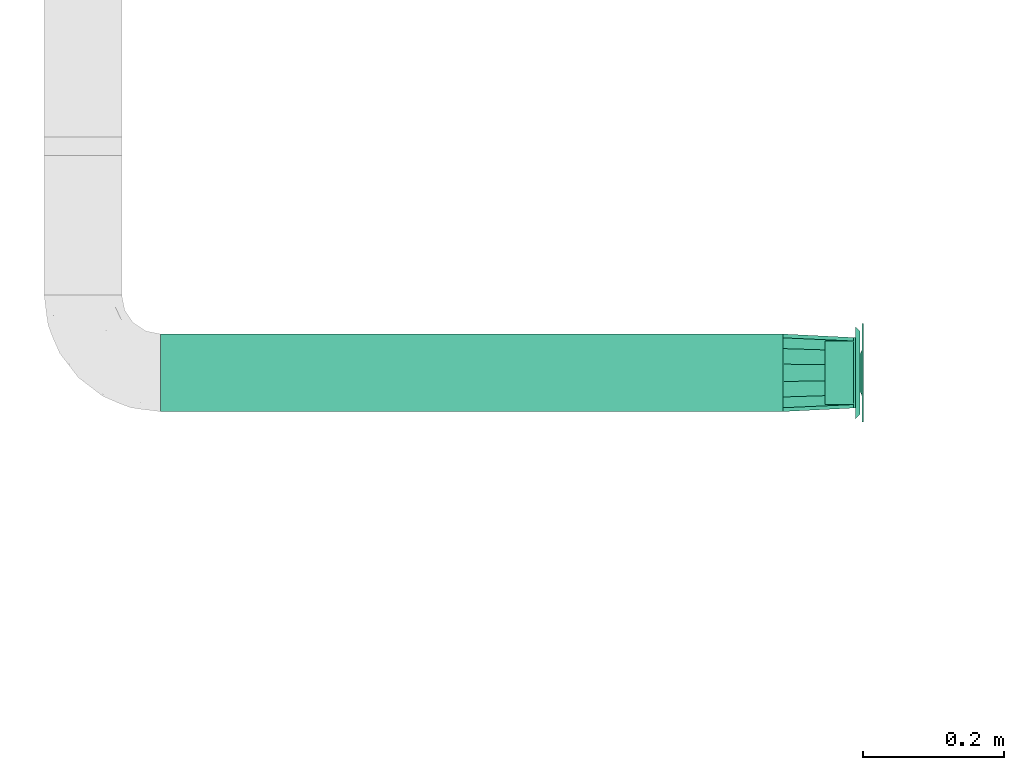
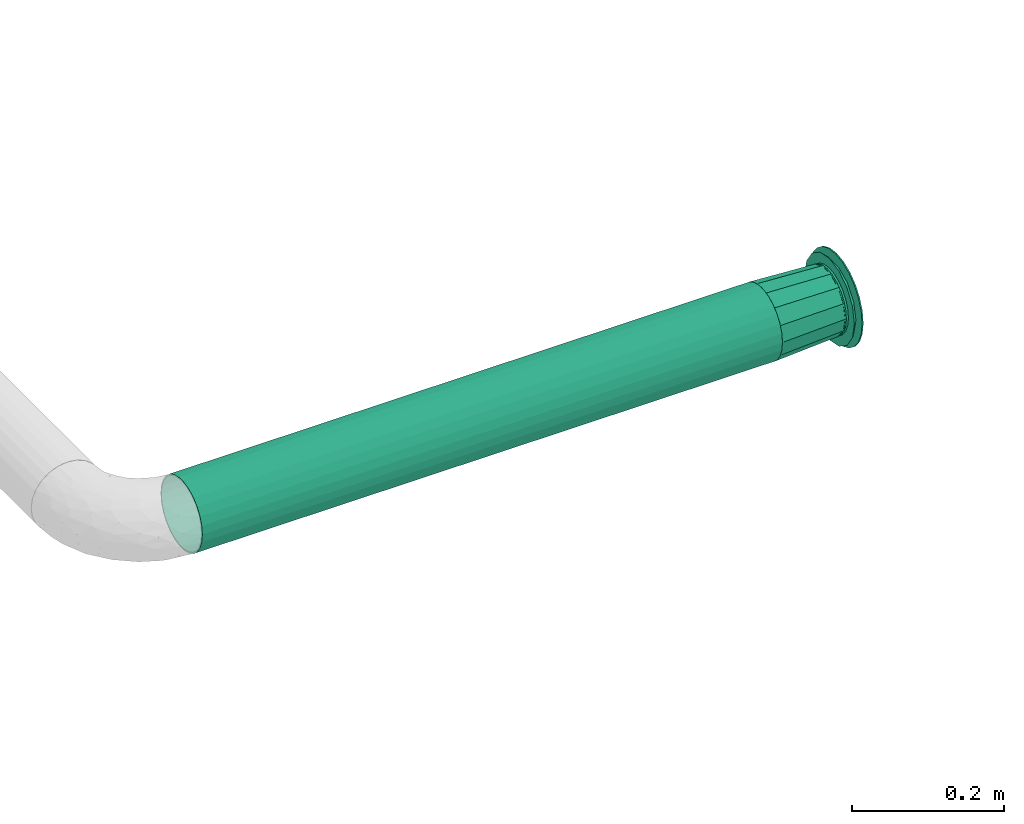
# One storey, part 21 of 103: 1 flow fitting, 1 flow segment, 1 flow terminal.
"""IFC2X3 building model written with IfcOpenShell, lengths in millimetres."""

from ifc_helpers import new_model, entity, si_unit, converted_unit, derived_unit, direction, frame, origin_with_axes, origin_2d_with_axis, place, context, subcontext, project, spatial, hollow_circle, extrude, open_shell, surface_model, source, transform, mapped, material, layer, layer_set, layer_usage, type_object, element, save


model = new_model("IFC2X3")

# Units and contexts
model_context = context("Model", 3, precision=1e-05, world=origin_with_axes(), true_north=direction((0.0, 1.0)))
body_context = subcontext(model_context, "Body", "Model", "MODEL_VIEW")
ifc_project = project(units=[si_unit("AREAUNIT", "SQUARE_METRE"), si_unit("VOLUMEUNIT", "CUBIC_METRE", prefix="DECI"), si_unit("TIMEUNIT", "SECOND"), si_unit("THERMODYNAMICTEMPERATUREUNIT", "DEGREE_CELSIUS"), si_unit("PRESSUREUNIT", "PASCAL"), si_unit("MASSUNIT", "GRAM", prefix="KILO"), si_unit("LENGTHUNIT", "METRE", prefix="MILLI"), si_unit("POWERUNIT", "WATT"), si_unit("ELECTRICCURRENTUNIT", "AMPERE"), si_unit("ELECTRICVOLTAGEUNIT", "VOLT"), derived_unit("VOLUMETRICFLOWRATEUNIT", [(si_unit("VOLUMEUNIT", "CUBIC_METRE", prefix="DECI"), 1), (si_unit("TIMEUNIT", "SECOND"), -1)]), derived_unit("LINEARVELOCITYUNIT", [(si_unit("LENGTHUNIT", "METRE"), 1), (si_unit("TIMEUNIT", "SECOND"), -1)]), derived_unit("MASSDENSITYUNIT", [(si_unit("MASSUNIT", "GRAM", prefix="KILO"), 1), (si_unit("VOLUMEUNIT", "CUBIC_METRE"), -1)]), converted_unit("PLANEANGLEUNIT", "DEGREE", entity("IfcRatioMeasure", 0.01745), si_unit("PLANEANGLEUNIT", "RADIAN"), dimensions=[0, 0, 0, 0, 0, 0, 0])], contexts=[model_context])

# Site, building, storey
site_placement = place(None, origin_with_axes())
site = spatial("IfcSite", under=ifc_project, at=site_placement, CompositionType="ELEMENT")
building_placement = place(site_placement, origin_with_axes())
building = spatial("IfcBuilding", under=site, at=building_placement, Name="mc-building", CompositionType="ELEMENT")
storey_placement = place(building_placement, frame((0.0, 0.0, 5900.0), z_axis=(0.0, 0.0, 1.0), x_axis=(1.0, 0.0, 0.0)))
storey = spatial("IfcBuildingStorey", under=building, at=storey_placement, Name="3. Korrus", CompositionType="ELEMENT", Elevation=5900.0)

# Flow terminal
air_terminal_type = type_object("IfcAirTerminalType", Name="100", PredefinedType="NOTDEFINED")
shared_shape_1 = source(origin_with_axes(), body_context, "Body", "SurfaceModel", [
    surface_model("IfcShellBasedSurfaceModel", [(11.2, 18.11733, -67.61481), (11.2, -18.11733, -67.61481), (11.2, 0.0, -70.0), (11.2, 67.61481, -18.11733), (11.2, 35.0, -60.62178), (11.2, 49.49747, -49.49747), (11.2, 60.62178, -35.0), (11.2, -67.61481, 18.11733), (11.2, -49.49747, -49.49747), (11.2, -67.61481, -18.11733), (11.2, -35.0, -60.62178), (11.2, -60.62178, -35.0), (11.2, -70.0, 0.0), (11.2, 18.11733, 67.61481), (11.2, 70.0, 0.0), (11.2, 67.61481, 18.11733), (11.2, 49.49747, 49.49747), (11.2, 60.62178, 35.0), (11.2, 35.0, 60.62178), (11.2, -49.49747, 49.49747), (11.2, -60.62178, 35.0), (11.2, -35.0, 60.62178), (11.2, -18.11733, 67.61481), (11.2, 0.0, 70.0), (9.2, 18.11733, 67.61481), (9.2, -67.61481, 18.11733), (9.2, 0.0, 70.0), (9.2, 49.49747, 49.49747), (9.2, 35.0, 60.62178), (9.2, 60.62178, 35.0), (9.2, 67.61481, 18.11733), (9.2, -35.0, 60.62178), (9.2, -49.49747, 49.49747), (9.2, -18.11733, 67.61481), (9.2, -60.62178, 35.0), (9.2, -67.61481, -18.11733), (9.2, -70.0, 0.0), (9.2, 67.61481, -18.11733), (9.2, 18.11733, -67.61481), (9.2, 49.49747, -49.49747), (9.2, 60.62178, -35.0), (9.2, 35.0, -60.62178), (9.2, -18.11733, -67.61481), (9.2, -49.49747, -49.49747), (9.2, -60.62178, -35.0), (9.2, -35.0, -60.62178), (9.2, 0.0, -70.0), (9.2, 70.0, 0.0), (9.2, 32.75, 0.0), (9.2, -16.375, 28.36233), (9.2, -28.36233, 16.375), (9.2, 16.375, 28.36233), (9.2, 0.0, 32.75), (9.2, 28.36233, 16.375), (9.2, -32.75, 0.0), (9.2, -16.375, -28.36233), (9.2, 16.375, -28.36233), (9.2, 0.0, -32.75), (9.2, 28.36233, -16.375), (9.2, -28.36233, -16.375), (6.2, -21.19625, -15.39997), (6.2, -21.19625, 15.39997), (6.2, 8.09625, 24.91768), (6.2, -8.09625, 24.91768), (6.2, -26.2, 0.0), (6.2, 21.19625, 15.39997), (6.2, -8.09625, -24.91768), (6.2, 21.19625, -15.39997), (6.2, 8.09625, -24.91768), (6.2, 26.2, 0.0), (9.2, 31.06579, -6.28555), (6.2, 23.69812, -7.69999), (6.2, -14.64625, -20.15883), (9.2, -22.36867, -22.36867), (6.2, -23.69812, -7.69999), (9.2, -31.06579, -6.28555), (6.2, 14.64625, -20.15883), (9.2, 8.1875, -30.55617), (6.2, 0.0, -24.91768), (9.2, 22.36867, -22.36867), (9.2, -8.1875, -30.55617), (9.2, -31.06579, 6.28555), (6.2, -23.69812, 7.69999), (6.2, 14.64625, 20.15883), (9.2, 22.36867, 22.36867), (6.2, 23.69812, 7.69999), (9.2, 31.06579, 6.28555), (6.2, -14.64625, 20.15883), (9.2, -8.1875, 30.55617), (6.2, 0.0, 24.91768), (9.2, -22.36867, 22.36867), (9.2, 8.1875, 30.55617), (6.2, -13.11761, 57.472), (6.2, -36.75472, 46.08897), (6.2, -53.11211, 25.57744), (6.2, 36.75472, 46.08897), (6.2, -58.95, 0.0), (6.2, 13.11761, 57.472), (6.2, 53.11211, 25.57744), (6.2, -53.11211, -25.57744), (6.2, -36.75472, -46.08897), (6.2, -13.11761, -57.472), (6.2, 58.95, 0.0), (6.2, 53.11211, -25.57744), (6.2, 13.11761, -57.472), (6.2, 36.75472, -46.08897), (0.0, -60.51411, 25.06576), (0.0, 0.0, 65.5), (0.0, 25.06576, 60.51411), (0.0, 46.3155, 46.3155), (0.0, 60.51411, 25.06576), (0.0, -46.3155, 46.3155), (0.0, -25.06576, 60.51411), (0.0, 0.0, -65.5), (0.0, -65.5, 0.0), (0.0, 65.5, 0.0), (0.0, 60.51411, -25.06576), (0.0, 46.3155, -46.3155), (0.0, 25.06576, -60.51411), (0.0, -46.3155, -46.3155), (0.0, -60.51411, -25.06576), (0.0, -25.06576, -60.51411), (6.2, 56.03105, -12.78872), (0.0, 53.4148, -35.69063), (0.0, 35.69063, -53.4148), (6.2, 24.93616, -51.78048), (0.0, -12.53288, -63.00706), (6.2, 0.0, -57.472), (0.0, -35.69063, -53.4148), (0.0, 63.00706, -12.53288), (6.2, 44.93342, -35.83321), (6.2, -24.93616, -51.78048), (6.2, -44.93342, -35.83321), (0.0, -53.4148, -35.69063), (0.0, 12.53288, -63.00706), (6.2, -56.03105, -12.78872), (0.0, -63.00706, -12.53288), (6.2, -56.03105, 12.78872), (0.0, -53.4148, 35.69063), (0.0, -35.69063, 53.4148), (6.2, -24.93616, 51.78048), (0.0, 12.53288, 63.00706), (6.2, 0.0, 57.472), (0.0, 35.69063, 53.4148), (0.0, -63.00706, 12.53288), (6.2, -44.93342, 35.83321), (6.2, 24.93616, 51.78048), (6.2, 44.93342, 35.83321), (0.0, 53.4148, 35.69063), (0.0, -12.53288, 63.00706), (6.2, 56.03105, 12.78872), (0.0, 63.00706, 12.53288), (-3.1, 12.94095, 48.29629), (-3.1, -35.35534, 35.35534), (-3.1, 0.0, 50.0), (-3.1, 35.35534, 35.35534), (-3.1, 25.0, 43.30127), (-3.1, -43.30127, 25.0), (-3.1, 43.30127, 25.0), (-3.1, -48.29629, -12.94095), (-3.1, -12.94095, 48.29629), (-3.1, -25.0, 43.30127), (-3.1, -50.0, 0.0), (-3.1, -48.29629, 12.94095), (-3.1, 48.29629, 12.94095), (-3.1, 12.94095, -48.29629), (-3.1, 50.0, 0.0), (-3.1, 48.29629, -12.94095), (-3.1, 35.35534, -35.35534), (-3.1, 43.30127, -25.0), (-3.1, 25.0, -43.30127), (-3.1, 0.0, -50.0), (-3.1, -35.35534, -35.35534), (-3.1, -43.30127, -25.0), (-3.1, -25.0, -43.30127), (-3.1, -12.94095, -48.29629), (0.0, 25.0, -43.30127), (0.0, 0.0, -50.0), (0.0, 12.94095, -48.29629), (0.0, 48.29629, -12.94095), (0.0, 35.35534, -35.35534), (0.0, -25.0, -43.30127), (0.0, 43.30127, -25.0), (0.0, -50.0, 0.0), (0.0, -12.94095, -48.29629), (0.0, -35.35534, -35.35534), (0.0, -48.29629, -12.94095), (0.0, -43.30127, -25.0), (0.0, 50.0, 0.0), (0.0, 43.30127, 25.0), (0.0, 12.94095, 48.29629), (0.0, 35.35534, 35.35534), (0.0, 25.0, 43.30127), (0.0, 0.0, 50.0), (0.0, -35.35534, 35.35534), (0.0, -43.30127, 25.0), (0.0, -48.29629, 12.94095), (0.0, -12.94095, 48.29629), (0.0, -25.0, 43.30127), (0.0, 48.29629, 12.94095), (-43.1, 0.0, 45.0), (-43.1, 11.64686, 43.46666), (-43.1, 22.5, 38.97115), (-43.1, -11.64686, 43.46666), (-43.1, 38.97115, 22.5), (-43.1, 43.46666, 11.64686), (-43.1, 31.81981, 31.81981), (-43.1, -22.5, 38.97115), (-43.1, -43.46666, 11.64686), (-43.1, -31.81981, 31.81981), (-43.1, -38.97115, 22.5), (-43.1, -45.0, 0.0), (-43.1, -43.46666, -11.64686), (-43.1, 45.0, 0.0), (-43.1, 43.46666, -11.64686), (-43.1, 38.97115, -22.5), (-43.1, 31.81981, -31.81981), (-43.1, 22.5, -38.97115), (-43.1, 11.64686, -43.46666), (-43.1, -31.81981, -31.81981), (-43.1, -38.97115, -22.5), (-43.1, -22.5, -38.97115), (-43.1, 0.0, -45.0), (-43.1, -11.64686, -43.46666), (-3.1, 22.5, -38.97115), (-3.1, 0.0, -45.0), (-3.1, 11.64686, -43.46666), (-3.1, 31.81981, -31.81981), (-3.1, -22.5, -38.97115), (-3.1, 38.97115, -22.5), (-3.1, 43.46666, -11.64686), (-3.1, 45.0, 0.0), (-3.1, -45.0, 0.0), (-3.1, -11.64686, -43.46666), (-3.1, -31.81981, -31.81981), (-3.1, -43.46666, -11.64686), (-3.1, -38.97115, -22.5), (-3.1, 0.0, 45.0), (-3.1, 43.46666, 11.64686), (-3.1, 38.97115, 22.5), (-3.1, 22.5, 38.97115), (-3.1, 31.81981, 31.81981), (-3.1, 11.64686, 43.46666), (-3.1, -11.64686, 43.46666), (-3.1, -43.46666, 11.64686), (-3.1, -31.81981, 31.81981), (-3.1, -38.97115, 22.5), (-3.1, -22.5, 38.97115)], [open_shell([[[0, 1, 2]], [[3, 0, 4]], [[5, 6, 3]], [[5, 3, 4]], [[7, 1, 0]], [[8, 7, 9]], [[10, 7, 8]], [[8, 9, 11]], [[12, 9, 7]], [[1, 7, 10]], [[7, 0, 3]], [[13, 14, 15]], [[16, 15, 17]], [[16, 18, 13]], [[16, 13, 15]], [[14, 13, 7]], [[7, 19, 20]], [[19, 7, 21]], [[7, 22, 21]], [[22, 7, 23]], [[7, 13, 23]], [[14, 7, 3]], [[24, 25, 26]], [[27, 24, 28]], [[27, 29, 30]], [[27, 30, 24]], [[25, 24, 30]], [[31, 25, 32]], [[25, 31, 33]], [[32, 25, 34]], [[33, 26, 25]], [[25, 35, 36]], [[25, 30, 37]], [[25, 37, 38]], [[39, 37, 40]], [[39, 41, 38]], [[39, 38, 37]], [[38, 42, 25]], [[35, 43, 44]], [[35, 25, 43]], [[45, 43, 25]], [[42, 45, 25]], [[38, 46, 42]], [[37, 30, 47]], [[35, 9, 36]], [[44, 11, 35]], [[10, 43, 45]], [[44, 43, 8]], [[1, 45, 42]], [[35, 11, 9]], [[9, 12, 36]], [[1, 10, 45]], [[8, 43, 10]], [[8, 11, 44]], [[2, 1, 42]], [[42, 46, 2]], [[38, 0, 46]], [[41, 4, 38]], [[6, 39, 40]], [[41, 39, 5]], [[3, 40, 37]], [[41, 5, 4]], [[4, 0, 38]], [[14, 3, 37]], [[6, 40, 3]], [[6, 5, 39]], [[47, 14, 37]], [[46, 0, 2]], [[30, 15, 47]], [[29, 17, 30]], [[18, 27, 28]], [[29, 27, 16]], [[13, 28, 24]], [[30, 17, 15]], [[15, 14, 47]], [[13, 18, 28]], [[16, 27, 18]], [[16, 17, 29]], [[23, 13, 24]], [[24, 26, 23]], [[33, 22, 26]], [[31, 21, 33]], [[20, 32, 34]], [[31, 32, 19]], [[7, 34, 25]], [[31, 19, 21]], [[21, 22, 33]], [[12, 7, 25]], [[20, 34, 7]], [[20, 19, 32]], [[36, 12, 25]], [[26, 22, 23]], [[48, 49, 50]], [[48, 51, 49]], [[49, 51, 52]], [[53, 51, 48]], [[48, 50, 54]], [[54, 55, 48]], [[56, 55, 57]], [[55, 58, 48]], [[58, 55, 56]], [[55, 54, 59]], [[60, 61, 62]], [[62, 61, 63]], [[64, 61, 60]], [[62, 65, 66]], [[67, 68, 65]], [[66, 60, 62]], [[65, 68, 66]], [[69, 67, 65]], [[69, 48, 70]], [[58, 71, 70]], [[72, 73, 60]], [[59, 74, 60]], [[75, 64, 74]], [[56, 68, 76]], [[72, 66, 55]], [[73, 72, 55]], [[68, 77, 78]], [[64, 75, 54]], [[59, 75, 74]], [[70, 71, 69]], [[67, 79, 76]], [[80, 55, 66]], [[68, 56, 77]], [[56, 76, 79]], [[79, 67, 58]], [[71, 58, 67]], [[80, 78, 57]], [[77, 57, 78]], [[66, 78, 80]], [[59, 60, 73]], [[64, 54, 81]], [[50, 82, 81]], [[83, 84, 65]], [[53, 85, 65]], [[86, 69, 85]], [[49, 63, 87]], [[83, 62, 51]], [[84, 83, 51]], [[63, 88, 89]], [[69, 86, 48]], [[53, 86, 85]], [[81, 82, 64]], [[61, 90, 87]], [[91, 51, 62]], [[63, 49, 88]], [[49, 87, 90]], [[90, 61, 50]], [[82, 50, 61]], [[91, 89, 52]], [[88, 52, 89]], [[62, 89, 91]], [[53, 65, 84]], [[92, 93, 94]], [[95, 94, 96]], [[97, 92, 95]], [[95, 92, 94]], [[96, 98, 95]], [[96, 99, 98]], [[99, 100, 101]], [[101, 102, 98]], [[102, 101, 103]], [[104, 105, 103]], [[101, 104, 103]], [[101, 98, 99]], [[106, 107, 108]], [[109, 110, 108]], [[106, 108, 110]], [[111, 112, 106]], [[106, 112, 107]], [[106, 113, 114]], [[106, 110, 113]], [[115, 116, 117]], [[117, 113, 110]], [[113, 117, 118]], [[114, 119, 120]], [[121, 119, 114]], [[121, 114, 113]], [[115, 117, 110]], [[103, 116, 122]], [[123, 116, 103]], [[124, 125, 118]], [[101, 126, 127]], [[100, 119, 128]], [[102, 122, 129]], [[103, 130, 123]], [[102, 129, 115]], [[113, 127, 126]], [[125, 124, 105]], [[130, 105, 117]], [[118, 125, 104]], [[124, 117, 105]], [[131, 100, 128]], [[119, 100, 132]], [[133, 99, 120]], [[134, 118, 104]], [[122, 116, 129]], [[127, 134, 104]], [[131, 121, 101]], [[99, 133, 132]], [[128, 121, 131]], [[130, 117, 123]], [[101, 121, 126]], [[99, 135, 120]], [[96, 136, 135]], [[136, 120, 135]], [[134, 127, 113]], [[133, 119, 132]], [[136, 96, 114]], [[94, 106, 137]], [[138, 106, 94]], [[139, 140, 112]], [[97, 141, 142]], [[95, 109, 143]], [[96, 137, 144]], [[94, 145, 138]], [[96, 144, 114]], [[107, 142, 141]], [[140, 139, 93]], [[145, 93, 111]], [[112, 140, 92]], [[139, 111, 93]], [[146, 95, 143]], [[109, 95, 147]], [[148, 98, 110]], [[149, 112, 92]], [[137, 106, 144]], [[142, 149, 92]], [[146, 108, 97]], [[98, 148, 147]], [[143, 108, 146]], [[145, 111, 138]], [[97, 108, 141]], [[98, 150, 110]], [[102, 151, 150]], [[151, 110, 150]], [[149, 142, 107]], [[148, 109, 147]], [[151, 102, 115]], [[152, 153, 154]], [[155, 152, 156]], [[157, 152, 158]], [[158, 152, 155]], [[158, 159, 157]], [[160, 153, 161]], [[160, 154, 153]], [[157, 162, 163]], [[153, 152, 157]], [[157, 159, 162]], [[158, 164, 159]], [[165, 166, 167]], [[168, 167, 169]], [[170, 165, 167]], [[170, 167, 168]], [[166, 165, 171]], [[159, 172, 173]], [[172, 159, 174]], [[174, 171, 175]], [[159, 164, 174]], [[166, 171, 174]], [[174, 164, 166]], [[176, 177, 178]], [[179, 176, 180]], [[176, 179, 181]], [[179, 180, 182]], [[179, 183, 181]], [[177, 181, 184]], [[177, 176, 181]], [[185, 186, 187]], [[186, 185, 181]], [[181, 183, 186]], [[183, 179, 188]], [[183, 188, 189]], [[190, 189, 191]], [[189, 190, 183]], [[190, 191, 192]], [[193, 194, 190]], [[183, 195, 196]], [[183, 190, 195]], [[194, 197, 198]], [[194, 195, 190]], [[197, 194, 193]], [[189, 188, 199]], [[164, 199, 166]], [[158, 189, 164]], [[192, 155, 156]], [[158, 155, 191]], [[190, 156, 152]], [[164, 189, 199]], [[199, 188, 166]], [[190, 192, 156]], [[191, 155, 192]], [[191, 189, 158]], [[193, 190, 152]], [[152, 154, 193]], [[160, 197, 154]], [[161, 198, 160]], [[195, 153, 157]], [[161, 153, 194]], [[196, 157, 163]], [[161, 194, 198]], [[198, 197, 160]], [[183, 196, 163]], [[195, 157, 196]], [[195, 194, 153]], [[162, 183, 163]], [[154, 197, 193]], [[159, 186, 162]], [[173, 187, 159]], [[181, 172, 174]], [[173, 172, 185]], [[184, 174, 175]], [[159, 187, 186]], [[186, 183, 162]], [[184, 181, 174]], [[185, 172, 181]], [[185, 187, 173]], [[177, 184, 175]], [[175, 171, 177]], [[165, 178, 171]], [[170, 176, 165]], [[182, 168, 169]], [[170, 168, 180]], [[179, 169, 167]], [[170, 180, 176]], [[176, 178, 165]], [[188, 179, 167]], [[182, 169, 179]], [[182, 180, 168]], [[166, 188, 167]], [[171, 178, 177]], [[200, 201, 202]], [[203, 200, 202]], [[204, 205, 202]], [[204, 202, 206]], [[203, 202, 205]], [[207, 208, 209]], [[207, 203, 205]], [[209, 208, 210]], [[211, 208, 212]], [[208, 207, 212]], [[207, 205, 212]], [[213, 214, 215]], [[205, 215, 212]], [[212, 216, 217]], [[216, 212, 215]], [[218, 219, 217]], [[212, 219, 220]], [[212, 217, 219]], [[221, 222, 223]], [[222, 221, 219]], [[218, 222, 219]], [[215, 205, 213]], [[224, 225, 226]], [[227, 228, 224]], [[229, 230, 231]], [[228, 227, 229]], [[229, 232, 228]], [[225, 228, 233]], [[225, 224, 228]], [[234, 235, 236]], [[235, 234, 228]], [[228, 232, 235]], [[232, 229, 231]], [[237, 238, 239]], [[240, 239, 241]], [[240, 242, 237]], [[240, 237, 239]], [[238, 237, 243]], [[244, 245, 246]], [[247, 244, 232]], [[244, 247, 245]], [[232, 238, 247]], [[238, 243, 247]], [[238, 232, 231]], [[205, 238, 213]], [[204, 239, 205]], [[240, 206, 202]], [[204, 206, 241]], [[242, 202, 201]], [[205, 239, 238]], [[238, 231, 213]], [[240, 202, 242]], [[241, 206, 240]], [[241, 239, 204]], [[201, 237, 242]], [[201, 200, 237]], [[243, 203, 207]], [[209, 247, 207]], [[246, 210, 208]], [[209, 210, 245]], [[244, 208, 211]], [[203, 243, 200]], [[207, 247, 243]], [[200, 243, 237]], [[209, 245, 247]], [[210, 246, 245]], [[244, 246, 208]], [[211, 232, 244]], [[212, 235, 211]], [[220, 236, 212]], [[228, 219, 221]], [[220, 219, 234]], [[233, 221, 223]], [[212, 236, 235]], [[235, 232, 211]], [[233, 228, 221]], [[234, 219, 228]], [[234, 236, 220]], [[225, 233, 223]], [[223, 222, 225]], [[226, 218, 217]], [[216, 224, 217]], [[229, 215, 214]], [[216, 215, 227]], [[230, 214, 213]], [[218, 226, 222]], [[217, 224, 226]], [[222, 226, 225]], [[216, 227, 224]], [[215, 229, 227]], [[230, 229, 214]], [[213, 231, 230]]])]),
])
flow_terminal_placement = place(storey_placement, frame((10289.07051, 3436.80698, 2345.0), z_axis=(0.0, 0.0, 1.0), x_axis=(1.0, 0.0, 0.0)))
element("IfcFlowTerminal", 1, at=flow_terminal_placement, inside=storey, type_object=air_terminal_type, Name="100", context=body_context, shape_type="MappedRepresentation", body=[
    mapped(shared_shape_1, transform((0.0, 0.0, 0.0), scale=1.0)),
])

# Flow segment
ifc_material = material(Name="FZ1")
ifc_layer = layer(ifc_material, 0.0)
ifc_layer_set = layer_set([ifc_layer], Name="FZ1")
ifc_layer_usage = layer_usage(ifc_layer_set, "AXIS1", "POSITIVE", 0.0)
duct_segment_type = type_object("IfcDuctSegmentType", Name="Safe", PredefinedType="RIGIDSEGMENT")
shared_shape_2 = source(origin_with_axes(), body_context, "Body", "SweptSolid", [
    extrude(hollow_circle(Radius=55.0, WallThickness=2.0, at=origin_2d_with_axis()), frame((0.0, 0.0, 0.0), z_axis=(1.0, 0.0, 0.0), x_axis=(0.0, 1.0, 0.0)), (0.0, 0.0, 1.0), 881.8),
])
flow_segment_placement = place(storey_placement, frame((9304.13313, 3436.80698, 2345.0), z_axis=(0.0, 0.0, 1.0), x_axis=(1.0, 0.0, 0.0)))
element("IfcFlowSegment", 2, at=flow_segment_placement, inside=storey, type_object=duct_segment_type, material=ifc_layer_usage, Name="Safe", context=body_context, shape_type="MappedRepresentation", body=[
    mapped(shared_shape_2, transform((0.0, 0.0, 0.0), scale=1.0)),
])

# Flow fitting
duct_fitting_type = type_object("IfcDuctFittingType", PredefinedType="TRANSITION")
shared_shape_3 = source(origin_with_axes(), body_context, "Body", "SurfaceModel", [
    surface_model("IfcShellBasedSurfaceModel", [(0.0, -53.12592, -14.23505), (2.0, -53.12592, -14.23505), (0.0, -55.0, 0.0), (0.0, -47.63139, -27.5), (2.0, -47.63139, -27.5), (2.0, -27.5, -47.63139), (0.0, -38.89087, -38.89087), (0.0, -27.5, -47.63139), (2.0, -38.89087, -38.89087), (2.0, -14.23505, -53.12592), (0.0, -14.23505, -53.12592), (2.0, -55.0, 0.0), (2.0, 0.0, -55.0), (0.0, 0.0, -55.0), (0.0, 14.23505, -53.12592), (2.0, 14.23505, -53.12592), (0.0, 27.5, -47.63139), (2.0, 27.5, -47.63139), (2.0, 47.63139, -27.5), (0.0, 38.89087, -38.89087), (0.0, 47.63139, -27.5), (2.0, 38.89087, -38.89087), (2.0, 53.12592, -14.23505), (0.0, 53.12592, -14.23505), (2.0, 55.0, 0.0), (0.0, 55.0, 0.0), (0.0, 53.12592, 14.23505), (2.0, 53.12592, 14.23505), (0.0, 47.63139, 27.5), (2.0, 47.63139, 27.5), (2.0, 27.5, 47.63139), (0.0, 38.89087, 38.89087), (0.0, 27.5, 47.63139), (2.0, 38.89087, 38.89087), (2.0, 14.23505, 53.12592), (0.0, 14.23505, 53.12592), (2.0, 0.0, 55.0), (0.0, 0.0, 55.0), (0.0, -14.23505, 53.12592), (2.0, -14.23505, 53.12592), (0.0, -27.5, 47.63139), (2.0, -27.5, 47.63139), (2.0, -47.63139, 27.5), (0.0, -38.89087, 38.89087), (0.0, -47.63139, 27.5), (2.0, -38.89087, 38.89087), (2.0, -53.12592, 14.23505), (0.0, -53.12592, 14.23505), (0.0, -49.55329, 23.86361), (0.0, 34.29194, 43.00073), (0.0, 49.55329, 23.86361), (0.0, -12.23865, -53.62104), (0.0, -34.29194, -43.00073), (0.0, 12.23865, -53.62104), (100.0, 11.12605, 48.7464), (100.0, -11.12605, 48.7464), (100.0, -31.17449, 39.09157), (100.0, 50.0, 0.0), (100.0, -45.04844, 21.69419), (100.0, 31.17449, 39.09157), (100.0, 45.04844, 21.69419), (100.0, 11.12605, -48.7464), (100.0, -45.04844, -21.69419), (100.0, -31.17449, -39.09157), (100.0, -11.12605, -48.7464), (100.0, 31.17449, -39.09157), (100.0, 45.04844, -21.69419), (100.0, -50.0, 0.0), (0.0, -12.23865, 53.62104), (0.0, 12.23865, 53.62104), (0.0, -34.29194, 43.00073), (0.0, 34.29194, -43.00073), (0.0, 49.55329, -23.86361), (0.0, -49.55329, -23.86361), (100.0, 47.52422, -10.84709), (100.0, 38.11147, -30.39288), (0.0, 23.2653, -48.31088), (0.0, 0.0, -53.62104), (0.0, 41.92261, -33.43217), (100.0, 0.0, -48.7464), (0.0, 52.32388, -11.72483), (100.0, 21.15027, -43.91899), (0.0, -23.2653, -48.31088), (0.0, -52.32388, -11.72483), (0.0, -41.92261, -33.43217), (100.0, -38.11147, -30.39288), (100.0, -47.52422, -10.84709), (100.0, -21.15027, -43.91899), (100.0, -47.52422, 10.84709), (100.0, -38.11147, 30.39288), (0.0, -23.2653, 48.31088), (0.0, 0.0, 53.62104), (0.0, -41.92261, 33.43217), (100.0, 0.0, 48.7464), (0.0, -52.32388, 11.72483), (100.0, -21.15027, 43.91899), (0.0, 23.2653, 48.31088), (0.0, 52.32388, 11.72483), (0.0, 41.92261, 33.43217), (100.0, 38.11147, 30.39288), (100.0, 47.52422, 10.84709), (100.0, 21.15027, 43.91899), (100.0, 12.94095, -48.29629), (100.0, 25.0, -43.30127), (100.0, 35.35534, -35.35534), (100.0, 43.30127, -25.0), (100.0, 48.29629, -12.94095), (100.0, 0.0, -50.0), (100.0, -25.0, -43.30127), (100.0, -12.94095, -48.29629), (100.0, -35.35534, -35.35534), (100.0, -48.29629, -12.94095), (100.0, -43.30127, -25.0), (100.0, -48.29629, 12.94095), (100.0, 48.29629, 12.94095), (100.0, 43.30127, 25.0), (100.0, 35.35534, 35.35534), (100.0, 12.94095, 48.29629), (100.0, 0.0, 50.0), (100.0, 25.0, 43.30127), (100.0, -35.35534, 35.35534), (100.0, -43.30127, 25.0), (100.0, -12.94095, 48.29629), (100.0, -25.0, 43.30127), (98.0, 48.29629, 12.94095), (98.0, 0.0, 50.0), (98.0, 12.94095, 48.29629), (98.0, 25.0, 43.30127), (98.0, 35.35534, 35.35534), (98.0, 43.30127, 25.0), (98.0, -35.35534, 35.35534), (98.0, -12.94095, 48.29629), (98.0, -25.0, 43.30127), (98.0, -48.29629, 12.94095), (98.0, -43.30127, 25.0), (98.0, -25.0, -43.30127), (98.0, -48.29629, -12.94095), (98.0, -50.0, 0.0), (98.0, 48.29629, -12.94095), (98.0, 12.94095, -48.29629), (98.0, 43.30127, -25.0), (98.0, 35.35534, -35.35534), (98.0, 25.0, -43.30127), (98.0, -35.35534, -35.35534), (98.0, -43.30127, -25.0), (98.0, -12.94095, -48.29629), (98.0, 0.0, -50.0), (98.0, 50.0, 0.0)], [open_shell([[[0, 1, 2]], [[3, 4, 0]], [[5, 6, 7]], [[3, 6, 8]], [[9, 7, 10]], [[0, 4, 1]], [[1, 11, 2]], [[9, 5, 7]], [[8, 6, 5]], [[8, 4, 3]], [[12, 9, 10]], [[10, 13, 12]], [[14, 15, 13]], [[16, 17, 14]], [[18, 19, 20]], [[16, 19, 21]], [[22, 20, 23]], [[16, 21, 17]], [[17, 15, 14]], [[24, 22, 23]], [[18, 20, 22]], [[18, 21, 19]], [[25, 24, 23]], [[13, 15, 12]], [[26, 27, 25]], [[28, 29, 26]], [[30, 31, 32]], [[28, 31, 33]], [[34, 32, 35]], [[26, 29, 27]], [[27, 24, 25]], [[34, 30, 32]], [[33, 31, 30]], [[33, 29, 28]], [[36, 34, 35]], [[35, 37, 36]], [[38, 39, 37]], [[40, 41, 38]], [[42, 43, 44]], [[40, 43, 45]], [[46, 44, 47]], [[40, 45, 41]], [[41, 39, 38]], [[11, 46, 47]], [[42, 44, 46]], [[42, 45, 43]], [[2, 11, 47]], [[37, 39, 36]], [[0, 2, 3]], [[48, 49, 50]], [[50, 2, 48]], [[51, 52, 2]], [[51, 2, 53]], [[37, 35, 32]], [[38, 37, 32]], [[38, 32, 28]], [[28, 32, 31]], [[7, 44, 28]], [[38, 43, 40]], [[38, 28, 43]], [[44, 2, 47]], [[43, 28, 44]], [[44, 3, 2]], [[25, 28, 26]], [[25, 23, 20]], [[25, 20, 16]], [[25, 16, 13]], [[16, 20, 19]], [[13, 16, 14]], [[3, 7, 6]], [[7, 13, 10]], [[3, 44, 7]], [[13, 7, 25]], [[28, 25, 7]], [[17, 12, 15]], [[21, 5, 17]], [[5, 18, 22]], [[21, 18, 5]], [[24, 5, 22]], [[12, 5, 9]], [[12, 17, 5]], [[5, 4, 8]], [[5, 24, 4]], [[11, 1, 4]], [[4, 24, 27]], [[29, 11, 27]], [[30, 29, 33]], [[30, 34, 36]], [[29, 30, 11]], [[36, 42, 30]], [[11, 42, 46]], [[11, 30, 42]], [[36, 41, 45]], [[45, 42, 36]], [[41, 36, 39]], [[27, 11, 4]], [[54, 55, 56]], [[57, 56, 58]], [[59, 54, 57]], [[57, 60, 59]], [[54, 56, 57]], [[58, 61, 57]], [[62, 63, 58]], [[64, 58, 63]], [[57, 65, 66]], [[57, 61, 65]], [[64, 61, 58]], [[62, 58, 67]], [[68, 69, 49]], [[68, 49, 70]], [[70, 49, 48]], [[50, 71, 2]], [[72, 71, 50]], [[71, 53, 2]], [[73, 2, 52]], [[25, 72, 50]], [[72, 74, 66]], [[75, 65, 71]], [[65, 76, 71]], [[77, 53, 61]], [[66, 78, 72]], [[79, 51, 77]], [[80, 57, 74]], [[78, 66, 75]], [[75, 71, 78]], [[81, 53, 76]], [[81, 61, 53]], [[51, 79, 64]], [[64, 82, 51]], [[67, 2, 83]], [[62, 73, 84]], [[84, 63, 85]], [[52, 63, 84]], [[67, 83, 86]], [[57, 80, 25]], [[87, 52, 82]], [[72, 80, 74]], [[86, 73, 62]], [[84, 85, 62]], [[76, 65, 81]], [[87, 63, 52]], [[77, 61, 79]], [[73, 86, 83]], [[82, 64, 87]], [[48, 88, 58]], [[89, 56, 70]], [[56, 90, 70]], [[91, 68, 55]], [[58, 92, 48]], [[93, 69, 91]], [[94, 67, 88]], [[92, 58, 89]], [[89, 70, 92]], [[95, 68, 90]], [[95, 55, 68]], [[69, 93, 54]], [[54, 96, 69]], [[57, 25, 97]], [[60, 50, 98]], [[98, 59, 99]], [[49, 59, 98]], [[57, 97, 100]], [[67, 94, 2]], [[101, 49, 96]], [[48, 94, 88]], [[100, 50, 60]], [[98, 99, 60]], [[90, 56, 95]], [[101, 59, 49]], [[91, 55, 93]], [[50, 100, 97]], [[96, 54, 101]], [[102, 103, 104]], [[102, 104, 105]], [[102, 106, 107]], [[106, 102, 105]], [[107, 106, 57]], [[107, 108, 109]], [[107, 57, 108]], [[110, 111, 112]], [[111, 110, 108]], [[108, 113, 111]], [[108, 57, 114]], [[114, 115, 116]], [[114, 116, 117]], [[117, 118, 114]], [[117, 116, 119]], [[114, 118, 120]], [[113, 120, 121]], [[67, 111, 113]], [[120, 122, 123]], [[108, 120, 113]], [[118, 122, 120]], [[108, 114, 120]], [[124, 125, 126]], [[124, 126, 127]], [[128, 129, 124]], [[128, 124, 127]], [[125, 124, 130]], [[131, 130, 132]], [[131, 125, 130]], [[130, 133, 134]], [[133, 130, 135]], [[136, 137, 133]], [[135, 130, 124]], [[124, 138, 135]], [[139, 138, 140]], [[141, 142, 139]], [[141, 139, 140]], [[135, 138, 139]], [[136, 143, 144]], [[143, 136, 135]], [[139, 145, 135]], [[136, 133, 135]], [[146, 145, 139]], [[138, 124, 147]], [[136, 111, 137]], [[144, 112, 136]], [[108, 143, 135]], [[144, 143, 110]], [[109, 135, 145]], [[136, 112, 111]], [[111, 67, 137]], [[109, 108, 135]], [[110, 143, 108]], [[110, 112, 144]], [[107, 109, 145]], [[145, 146, 107]], [[139, 102, 146]], [[142, 103, 139]], [[105, 141, 140]], [[142, 141, 104]], [[106, 140, 138]], [[142, 104, 103]], [[103, 102, 139]], [[57, 106, 138]], [[105, 140, 106]], [[105, 104, 141]], [[147, 57, 138]], [[146, 102, 107]], [[124, 114, 147]], [[129, 115, 124]], [[119, 128, 127]], [[129, 128, 116]], [[117, 127, 126]], [[124, 115, 114]], [[114, 57, 147]], [[117, 119, 127]], [[116, 128, 119]], [[116, 115, 129]], [[118, 117, 126]], [[126, 125, 118]], [[131, 122, 125]], [[132, 123, 131]], [[121, 130, 134]], [[132, 130, 120]], [[113, 134, 133]], [[132, 120, 123]], [[123, 122, 131]], [[67, 113, 133]], [[121, 134, 113]], [[121, 120, 130]], [[137, 67, 133]], [[125, 122, 118]]])]),
])
flow_fitting_placement = place(storey_placement, frame((10185.97051, 3436.80698, 2345.0), z_axis=(0.0, 0.0, 1.0), x_axis=(1.0, 0.0, 0.0)))
element("IfcFlowFitting", 3, at=flow_fitting_placement, inside=storey, type_object=duct_fitting_type, context=body_context, shape_type="MappedRepresentation", body=[
    mapped(shared_shape_3, transform((0.0, 0.0, 0.0), scale=1.0)),
])

save(model, "model.ifc")
